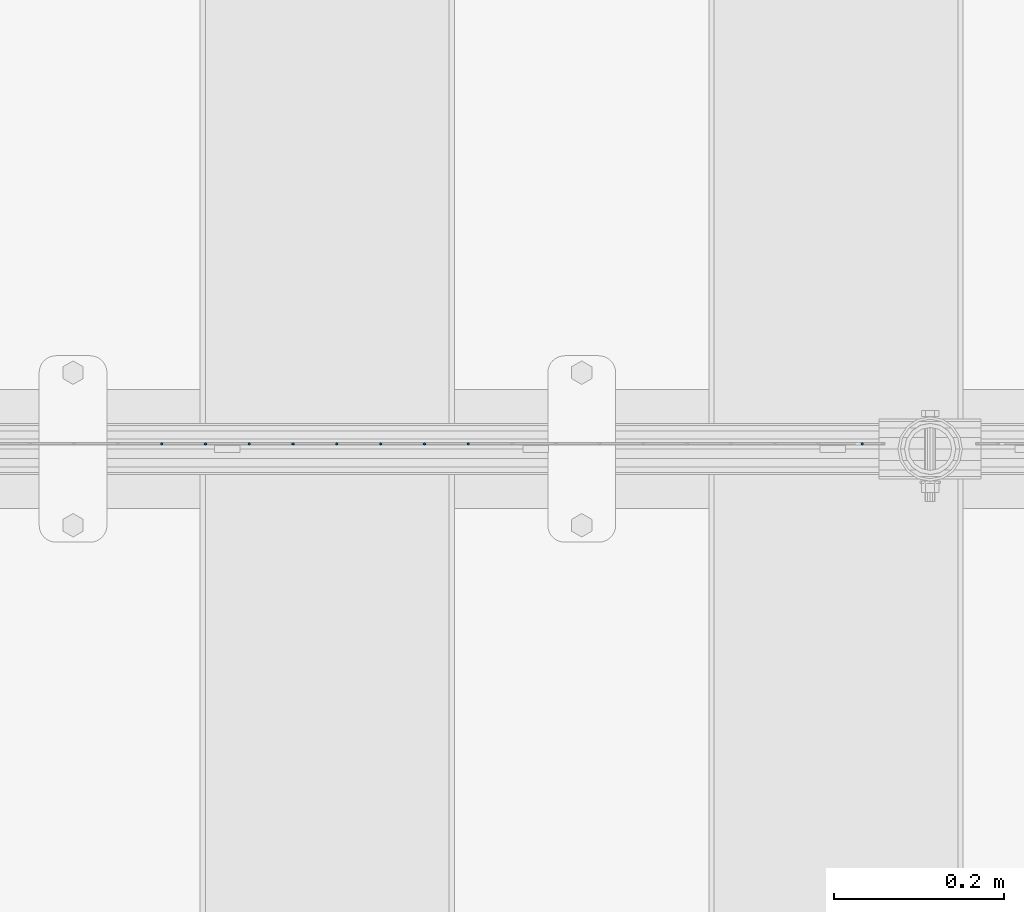
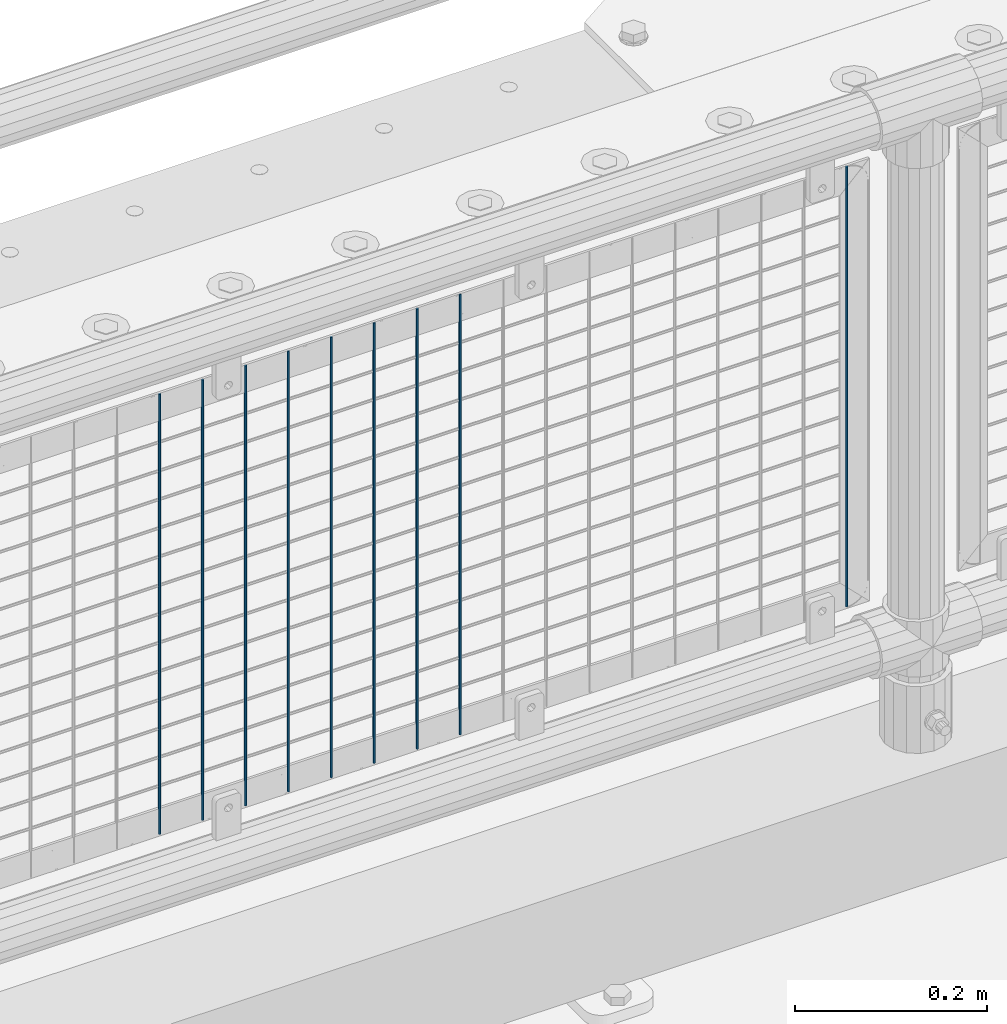
# One storey, part 86 of 240: 9 columns.
"""IFC2X3 building model written with IfcOpenShell, lengths in millimetres."""

from ifc_helpers import new_model, si_unit, frame, origin_with_axes, place, context, subcontext, project, spatial, faceted_brep, material, type_object, element, save


model = new_model("IFC2X3")

# Units and contexts
model_context = context("Model", 3, precision=1e-05, world=origin_with_axes())
body_context = subcontext(model_context, "Body", "Model", "MODEL_VIEW")
ifc_project = project(units=[si_unit("LENGTHUNIT", "METRE", prefix="MILLI"), si_unit("AREAUNIT", "SQUARE_METRE"), si_unit("VOLUMEUNIT", "CUBIC_METRE"), si_unit("MASSUNIT", "GRAM", prefix="KILO"), si_unit("TIMEUNIT", "SECOND"), si_unit("PLANEANGLEUNIT", "RADIAN"), si_unit("SOLIDANGLEUNIT", "STERADIAN"), si_unit("THERMODYNAMICTEMPERATUREUNIT", "DEGREE_CELSIUS"), si_unit("LUMINOUSINTENSITYUNIT", "LUMEN")], contexts=[model_context])

# Site, building, storey
site_placement = place(None, origin_with_axes())
site = spatial("IfcSite", under=ifc_project, at=site_placement, CompositionType="ELEMENT")
building_placement = place(site_placement, origin_with_axes())
building = spatial("IfcBuilding", under=site, at=building_placement, Name="Standard", CompositionType="ELEMENT")
storey_placement = place(building_placement, origin_with_axes())
storey = spatial("IfcBuildingStorey", under=building, at=storey_placement, Name="Undefined", CompositionType="ELEMENT", Elevation=0.0)

# Columns
ifc_material = material(Name="Misc_Undefined")
column_type = type_object("IfcColumnType", Name="D3", PredefinedType="NOTDEFINED")
for number, where, z_axis, x_axis in (
    (1, (50816.1, 34670.5, 353.020000000001), (-1.0, 0.0, 0.0), (0.0, 0.0, 1.0)),
    (2, (50764.445, 34670.5, 353.020000000001), (-1.0, 0.0, 0.0), (0.0, 0.0, 1.0)),
    (3, (50712.79, 34670.5, 353.020000000001), (-1.0, 0.0, 0.0), (0.0, 0.0, 1.0)),
    (4, (50661.135, 34670.5, 353.020000000001), (-1.0, 0.0, 0.0), (0.0, 0.0, 1.0)),
    (5, (50609.48, 34670.5, 353.020000000001), (-1.0, 0.0, 0.0), (0.0, 0.0, 1.0)),
    (6, (50557.825, 34670.5, 353.020000000001), (-1.0, 0.0, 0.0), (0.0, 0.0, 1.0)),
    (7, (50506.17, 34670.5, 353.020000000001), (-1.0, 0.0, 0.0), (0.0, 0.0, 1.0)),
    (8, (50454.515, 34670.5, 353.020000000001), (-1.0, 0.0, 0.0), (0.0, 0.0, 1.0)),
    (9, (51280.995, 34670.5, 353.020000000001), (-1.0, 0.0, 0.0), (0.0, 0.0, 1.0)),
):
    element("IfcColumn", number, at=place(storey_placement, frame(where, z_axis=z_axis, x_axis=x_axis)), inside=storey, type_object=column_type, material=ifc_material, ObjectType="D3", context=body_context, shape_type="Brep", body=[
        faceted_brep([(-7.27595761418343e-12, -1.49999999999272, 0.0), (-7.27595761418343e-12, -0.749999999992724, -1.29903810567669), (560.0, -0.75, -1.29903810567339), (560.0, -1.5, 0.0), (0.0, 0.750000000007276, -1.29903810567669), (560.0, 0.75, -1.29903810567339), (0.0, 1.50000000000728, 0.0), (560.0, 1.5, 0.0), (0.0, 0.750000000007276, 1.29903810567669), (560.0, 0.75, 1.29903810567339), (-7.27595761418343e-12, -0.749999999992724, 1.29903810567669), (560.0, -0.75, 1.29903810567339)], [[[0, 1, 2, 3]], [[1, 4, 5, 2]], [[4, 6, 7, 5]], [[6, 8, 9, 7]], [[8, 10, 11, 9]], [[10, 0, 3, 11]], [[5, 7, 9, 11, 3, 2]], [[10, 8, 6, 4, 1, 0]]]),
    ])

save(model, "model.ifc")
